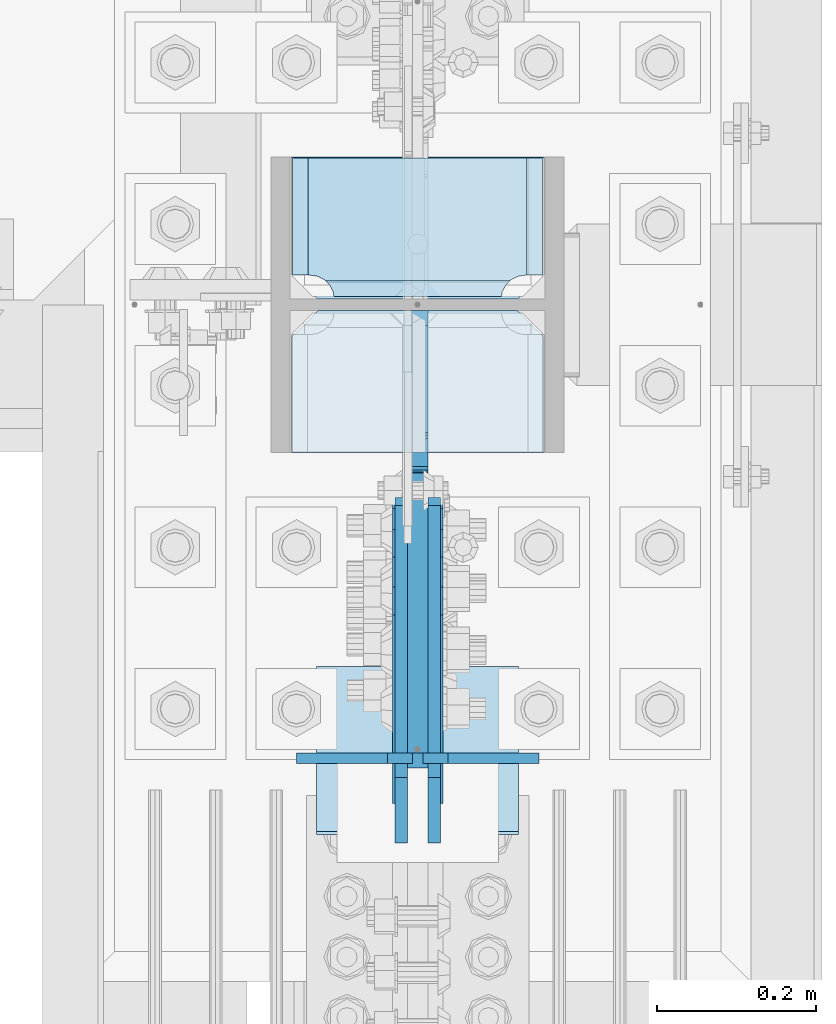
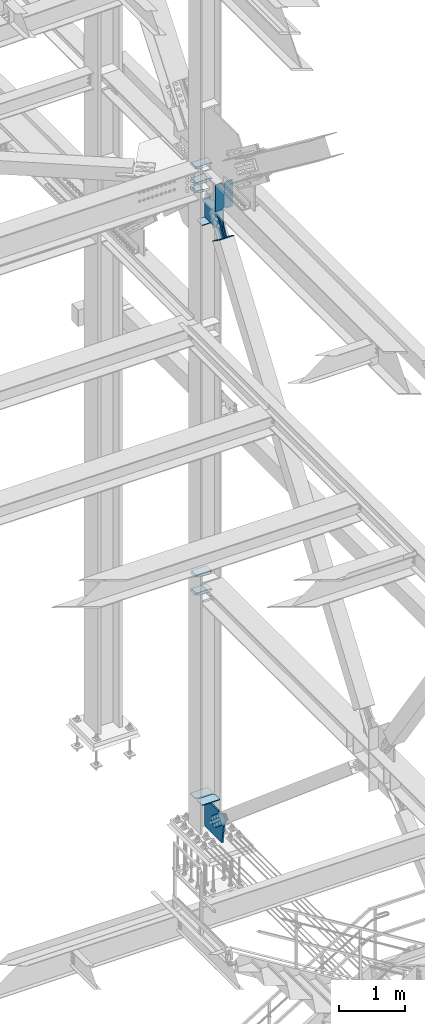
# One storey, part 3581 of 3843: 17 plates, 7 elements without a shape of their own.
"""IFC2X3 building model written with IfcOpenShell, lengths in millimetres."""

from ifc_helpers import new_model, si_unit, frame, origin_with_axes, place, context, subcontext, project, spatial, faceted_brep, material, type_object, element, aggregate, save


model = new_model("IFC2X3")

# Units and contexts
model_context = context("Model", 3, precision=1e-05, world=origin_with_axes())
body_context = subcontext(model_context, "Body", "Model", "MODEL_VIEW")
ifc_project = project(units=[si_unit("LENGTHUNIT", "METRE", prefix="MILLI"), si_unit("AREAUNIT", "SQUARE_METRE"), si_unit("VOLUMEUNIT", "CUBIC_METRE"), si_unit("MASSUNIT", "GRAM", prefix="KILO"), si_unit("TIMEUNIT", "SECOND"), si_unit("PLANEANGLEUNIT", "RADIAN"), si_unit("SOLIDANGLEUNIT", "STERADIAN"), si_unit("THERMODYNAMICTEMPERATUREUNIT", "DEGREE_CELSIUS"), si_unit("LUMINOUSINTENSITYUNIT", "LUMEN")], contexts=[model_context])

# Site, building, storey
site_placement = place(None, origin_with_axes())
site = spatial("IfcSite", under=ifc_project, at=site_placement, CompositionType="ELEMENT")
building_placement = place(site_placement, origin_with_axes())
building = spatial("IfcBuilding", under=site, at=building_placement, Name="Undefined", CompositionType="ELEMENT")
storey_placement = place(building_placement, origin_with_axes())
storey = spatial("IfcBuildingStorey", under=building, at=storey_placement, Name="Undefined", CompositionType="ELEMENT", Elevation=0.0)

# Assembly, plates
assembly_1_placement = place(storey_placement, origin_with_axes())
assembly_1 = element("IfcElementAssembly", 1, at=assembly_1_placement, inside=storey, Name="COLUMN", AssemblyPlace="NOTDEFINED", PredefinedType="RIGID_FRAME")
ifc_material_1 = material(Name="STEEL/A572-50")
plate_type_1 = type_object("IfcPlateType", PredefinedType="NOTDEFINED")
plate_1_placement = place(assembly_1_placement, frame((85807.55, 25608.75625, 41459.7600749074), z_axis=(0.0, -1.0, 0.0), x_axis=(-1.0, 0.0, 0.0)))
plate_1 = element("IfcPlate", 2, at=plate_1_placement, type_object=plate_type_1, material=ifc_material_1, Name="CB_COL", context=body_context, shape_type="Brep", body=[
    faceted_brep([(0.0, -6.34999999999854, 33.3375015258789), (0.0, -6.34999999999854, 178.59375), (0.0, 6.34999999999854, 178.59375), (0.0, 6.34999999999854, 33.3375015258789), (317.499999999985, -6.34999999999854, 178.59375), (317.499999999985, 6.34999999999854, 178.59375), (317.499999999985, -6.34999999999854, 33.3375015258789), (317.499999999985, 6.34999999999854, 33.3375015258789), (284.162498474107, -6.34999999999854, 0.0), (284.162498474107, 6.34999999999854, 0.0), (33.3375015258789, -6.34999999999854, 0.0), (33.3375015258789, 6.34999999999854, 0.0)], [[[0, 1, 2, 3]], [[1, 4, 5, 2]], [[4, 6, 7, 5]], [[6, 8, 9, 7]], [[8, 10, 11, 9]], [[10, 0, 3, 11]], [[5, 7, 9, 11, 3, 2]], [[10, 8, 6, 4, 1, 0]]]),
])
plate_2_placement = place(assembly_1_placement, frame((85807.55, 25623.04375, 30669.9559976022), z_axis=(0.0, 1.0, 0.0), x_axis=(-1.0, 0.0, 0.0)))
plate_2 = element("IfcPlate", 3, at=plate_2_placement, type_object=plate_type_1, material=ifc_material_1, Name="CB_COL", context=body_context, shape_type="Brep", body=[
    faceted_brep([(0.0, -6.34999999999854, 33.3375015258789), (0.0, -6.34999999999854, 178.59375), (0.0, 6.34999999999854, 178.59375), (0.0, 6.34999999999854, 33.3375015258789), (317.499999999985, -6.34999999999854, 178.59375), (317.499999999985, 6.34999999999854, 178.59375), (317.499999999985, -6.34999999999854, 33.3375015258789), (317.499999999985, 6.34999999999854, 33.3375015258789), (284.162498474107, -6.34999999999854, 0.0), (284.162498474107, 6.34999999999854, 0.0), (33.3375015258789, -6.34999999999854, 0.0), (33.3375015258789, 6.34999999999854, 0.0)], [[[0, 1, 2, 3]], [[1, 4, 5, 2]], [[4, 6, 7, 5]], [[6, 8, 9, 7]], [[8, 10, 11, 9]], [[10, 0, 3, 11]], [[5, 7, 9, 11, 3, 2]], [[10, 8, 6, 4, 1, 0]]]),
])
plate_3_placement = place(assembly_1_placement, frame((85807.55, 25608.75625, 30669.9559976022), z_axis=(0.0, -1.0, 0.0), x_axis=(-1.0, 0.0, 0.0)))
plate_3 = element("IfcPlate", 4, at=plate_3_placement, type_object=plate_type_1, material=ifc_material_1, Name="CB_COL", context=body_context, shape_type="Brep", body=[
    faceted_brep([(0.0, -6.34999999999854, 33.3375015258789), (0.0, -6.34999999999854, 178.59375), (0.0, 6.34999999999854, 178.59375), (0.0, 6.34999999999854, 33.3375015258789), (317.499999999985, -6.34999999999854, 178.59375), (317.499999999985, 6.34999999999854, 178.59375), (317.499999999985, -6.34999999999854, 33.3375015258789), (317.499999999985, 6.34999999999854, 33.3375015258789), (284.162498474107, -6.34999999999854, 0.0), (284.162498474107, 6.34999999999854, 0.0), (33.3375015258789, -6.34999999999854, 0.0), (33.3375015258789, 6.34999999999854, 0.0)], [[[0, 1, 2, 3]], [[1, 4, 5, 2]], [[4, 6, 7, 5]], [[6, 8, 9, 7]], [[8, 10, 11, 9]], [[10, 0, 3, 11]], [[5, 7, 9, 11, 3, 2]], [[10, 8, 6, 4, 1, 0]]]),
])
plate_type_2 = type_object("IfcPlateType", PredefinedType="NOTDEFINED")
plate_4_placement = place(assembly_1_placement, frame((85809.1375, 25800.84375, 42103.675), z_axis=(-1.0, 0.0, 0.0), x_axis=(0.0, -1.0, 0.0)))
plate_4 = element("IfcPlate", 5, at=plate_4_placement, type_object=plate_type_2, material=ifc_material_1, Name="PLATE", context=body_context, shape_type="Brep", body=[
    faceted_brep([(160.070927103505, 9.33339379637619, 49.8019750199746), (156.294129000915, 15.875, 46.0251769173919), (156.294129000915, 15.875, 274.649823082611), (160.070927103505, 9.33339379638346, 270.873024980028), (168.479274789282, -5.2302916030967, 266.588757845922), (174.625000047685, -15.875, 265.615370590487), (174.625000047685, -15.875, 55.0596294095158), (168.479274789282, -5.2302916030967, 54.0862421540805), (147.637499618526, 15.875, 21.5063709990791), (147.637499618526, -15.875, 3.17549995230729), (0.0, -15.875, 3.17549995230729), (0.0, 15.875, 21.5063709990791), (0.0, 15.875, 299.169629000906), (0.0, -15.875, 317.500500047678), (147.637499618526, -15.875, 317.500500047678), (147.637499618526, 15.875, 299.169629000906), (147.637499618531, -15.875, 295.275000381473), (147.637499618531, 15.875, 295.275000381473), (149.113757464449, -15.875, 285.954275170763), (149.113757464449, 15.875, 285.954275170763), (153.398024598551, -15.875, 277.545927484985), (153.398024598551, 15.875, 277.545927484985), (160.070927103507, -15.875, 270.873024980028), (168.479274789286, -15.875, 266.588757845922), (168.479274789286, -15.875, 54.0862421540805), (160.070927103507, -15.875, 49.8019750199746), (153.398024598551, -15.875, 43.1290725150175), (153.398024598551, 15.875, 43.1290725150175), (149.113757464449, -15.875, 34.7207248292398), (149.113757464449, 15.875, 34.7207248292398), (147.637499618531, -15.875, 25.3999996185303), (147.637499618531, 15.875, 25.3999996185303)], [[[0, 1, 2, 3, 4, 5, 6, 7]], [[8, 9, 10, 11]], [[12, 13, 14, 15]], [[13, 12, 11, 10]], [[16, 17, 15, 14]], [[16, 18, 19, 17]], [[18, 20, 21, 19]], [[21, 20, 22, 3, 2]], [[22, 23, 4, 3]], [[23, 5, 4]], [[24, 7, 6]], [[24, 25, 0, 7]], [[25, 26, 27, 1, 0]], [[26, 28, 29, 27]], [[28, 30, 31, 29]], [[31, 30, 9, 8]], [[27, 29, 31, 8, 11, 12, 15, 17, 19, 21, 2, 1]], [[9, 30, 28, 26, 25, 24, 6, 5, 23, 22, 20, 18, 16, 14, 13, 10]]]),
])
plate_5_placement = place(assembly_1_placement, frame((85809.1375, 25800.84375, 42389.425), z_axis=(-1.0, 0.0, 0.0), x_axis=(0.0, -1.0, 0.0)))
plate_5 = element("IfcPlate", 6, at=plate_5_placement, type_object=plate_type_2, material=ifc_material_1, Name="PLATE", context=body_context, shape_type="Brep", body=[
    faceted_brep([(160.070927103505, 9.33339379637619, 49.8019750199746), (156.294129000915, 15.875, 46.0251769173919), (156.294129000915, 15.875, 274.649823082611), (160.070927103505, 9.33339379638346, 270.873024980028), (168.479274789282, -5.2302916030967, 266.588757845922), (174.625000047685, -15.875, 265.615370590487), (174.625000047685, -15.875, 55.0596294095158), (168.479274789282, -5.2302916030967, 54.0862421540805), (147.637499618526, 15.875, 21.5063709990791), (147.637499618526, -15.875, 3.17549995230729), (0.0, -15.875, 3.17549995230729), (0.0, 15.875, 21.5063709990791), (0.0, 15.875, 299.169629000906), (0.0, -15.875, 317.500500047678), (147.637499618526, -15.875, 317.500500047678), (147.637499618526, 15.875, 299.169629000906), (147.637499618531, -15.875, 295.275000381473), (147.637499618531, 15.875, 295.275000381473), (149.113757464449, -15.875, 285.954275170763), (149.113757464449, 15.875, 285.954275170763), (153.398024598551, -15.875, 277.545927484985), (153.398024598551, 15.875, 277.545927484985), (160.070927103507, -15.875, 270.873024980028), (168.479274789286, -15.875, 266.588757845922), (168.479274789286, -15.875, 54.0862421540805), (160.070927103507, -15.875, 49.8019750199746), (153.398024598551, -15.875, 43.1290725150175), (153.398024598551, 15.875, 43.1290725150175), (149.113757464449, -15.875, 34.7207248292398), (149.113757464449, 15.875, 34.7207248292398), (147.637499618531, -15.875, 25.3999996185303), (147.637499618531, 15.875, 25.3999996185303)], [[[0, 1, 2, 3, 4, 5, 6, 7]], [[8, 9, 10, 11]], [[12, 13, 14, 15]], [[13, 12, 11, 10]], [[16, 17, 15, 14]], [[16, 18, 19, 17]], [[18, 20, 21, 19]], [[21, 20, 22, 3, 2]], [[22, 23, 4, 3]], [[23, 5, 4]], [[24, 7, 6]], [[24, 25, 0, 7]], [[25, 26, 27, 1, 0]], [[26, 28, 29, 27]], [[28, 30, 31, 29]], [[31, 30, 9, 8]], [[27, 29, 31, 8, 11, 12, 15, 17, 19, 21, 2, 1]], [[9, 30, 28, 26, 25, 24, 6, 5, 23, 22, 20, 18, 16, 14, 13, 10]]]),
])
plate_type_3 = type_object("IfcPlateType", PredefinedType="NOTDEFINED")
plate_6_placement = place(assembly_1_placement, frame((85488.4625, 25623.04375, 41941.75), z_axis=(0.0, 1.0, 0.0), x_axis=(1.0, 0.0, 0.0)))
plate_6 = element("IfcPlate", 7, at=plate_6_placement, type_object=plate_type_3, material=ifc_material_1, Name="PLATE", context=body_context, shape_type="Brep", body=[
    faceted_brep([(21.5053709991043, -15.875, 177.799788052507), (3.17449995233619, 15.875, 177.799755617103), (3.17449995233619, 15.875, 30.1625003814697), (21.5053709991043, -15.875, 30.1625003814661), (54.0862421540805, 5.23029160311853, 9.32072521070586), (55.0596294095158, 15.875, 3.17499995233084), (131.762500739671, 15.875, 3.17499995228718), (147.637500024415, -11.6213053312968, 19.0499992370314), (147.637500024415, -15.875, 21.5058709990553), (46.0251769173774, -15.875, 21.5058709990954), (49.8019750199892, -9.33339379635436, 17.7290728964872), (147.63750002443, -15.875, 177.799999999988), (147.63750002443, 15.875, 177.799999999988), (147.637500024415, 15.875, 19.0499992370314), (54.0862421540805, 15.875, 9.32072521070586), (49.8019750199892, 15.875, 17.7290728964872), (43.129072515032, -15.875, 24.4019754014407), (43.129072515032, 15.875, 24.4019754014407), (34.7207248292543, -15.875, 28.6862425355466), (34.7207248292543, 15.875, 28.6862425355466), (25.3999996185303, -15.875, 30.1625003814661), (25.3999996185303, 15.875, 30.1625003814661)], [[[0, 1, 2, 3]], [[4, 5, 6, 7, 8, 9, 10]], [[11, 12, 1, 0]], [[13, 12, 11, 8, 7]], [[13, 7, 6]], [[14, 5, 4]], [[15, 14, 4, 10]], [[16, 17, 15, 10, 9]], [[16, 18, 19, 17]], [[18, 20, 21, 19]], [[21, 20, 3, 2]], [[12, 13, 6, 5, 14, 15, 17, 19, 21, 2, 1]], [[20, 18, 16, 9, 8, 11, 0, 3]]]),
])
plate_type_4 = type_object("IfcPlateType", PredefinedType="NOTDEFINED")
plate_7_placement = place(assembly_1_placement, frame((85488.4625, 25623.04375, 34459.8625), z_axis=(1.0, 0.0, 0.0), x_axis=(0.0, 1.0, 0.0)))
plate_7 = element("IfcPlate", 8, at=plate_7_placement, type_object=plate_type_4, material=ifc_material_1, Name="PLATE", context=body_context, shape_type="Brep", body=[
    faceted_brep([(17.7290728964945, 7.7467605847196, 270.873024980028), (23.3384576632816, 17.4625000000015, 276.482409746808), (23.3384576632816, 17.4625000000015, 44.1925902531948), (17.7290728964945, 7.7467605847196, 49.8019750199746), (9.32072521071677, -6.81692481475329, 54.0862421540805), (3.174499952318, -17.4625000000015, 55.0597086017369), (3.174499952318, -17.4625000000015, 265.615291398266), (9.32072521071677, -6.81692481475329, 266.588757845922), (30.1625003814697, 17.4625000000015, 297.335542336717), (30.1625003814697, -17.4625000000015, 317.499500047677), (177.800000000001, -17.4625000000015, 317.499500047677), (177.800000000001, 17.4625000000015, 297.335542336717), (177.800000000001, 17.4625000000015, 23.338457663267), (177.800000000001, -17.4625000000015, 3.17449995230709), (30.1625003814697, -17.4625000000015, 3.17449995230709), (30.1625003814697, 17.4625000000015, 23.338457663267), (9.32072521071677, -17.4625000000015, 266.588757845922), (17.7290728964945, -17.4625000000015, 270.873024980028), (24.4019754014498, -17.4625000000015, 277.545927484985), (24.4019754014498, 17.4625000000015, 277.545927484985), (28.6862425355521, -17.4625000000015, 285.954275170763), (28.6862425355521, 17.4625000000015, 285.954275170763), (30.1625003814697, -17.4625000000015, 295.275000381473), (30.1625003814697, 17.4625000000015, 295.275000381473), (30.1625003814697, -17.4625000000015, 25.3999996185303), (30.1625003814697, 17.4625000000015, 25.3999996185303), (28.6862425355521, -17.4625000000015, 34.7207248292398), (28.6862425355521, 17.4625000000015, 34.7207248292398), (24.4019754014498, -17.4625000000015, 43.1290725150175), (24.4019754014498, 17.4625000000015, 43.1290725150175), (17.7290728964945, -17.4625000000015, 49.8019750199746), (9.32072521071495, -17.4625000000015, 54.0862421540805)], [[[0, 1, 2, 3, 4, 5, 6, 7]], [[8, 9, 10, 11]], [[12, 13, 14, 15]], [[16, 7, 6]], [[16, 17, 0, 7]], [[17, 18, 19, 1, 0]], [[18, 20, 21, 19]], [[20, 22, 23, 21]], [[23, 22, 9, 8]], [[11, 10, 13, 12]], [[24, 25, 15, 14]], [[24, 26, 27, 25]], [[26, 28, 29, 27]], [[29, 28, 30, 3, 2]], [[30, 31, 4, 3]], [[31, 5, 4]], [[19, 21, 23, 8, 11, 12, 15, 25, 27, 29, 2, 1]], [[31, 30, 28, 26, 24, 14, 13, 10, 9, 22, 20, 18, 17, 16, 6, 5]]]),
])
plate_8_placement = place(assembly_1_placement, frame((85488.4625, 25623.04375, 34793.2375), z_axis=(1.0, 0.0, 0.0), x_axis=(0.0, 1.0, 0.0)))
plate_8 = element("IfcPlate", 9, at=plate_8_placement, type_object=plate_type_4, material=ifc_material_1, Name="PLATE", context=body_context, shape_type="Brep", body=[
    faceted_brep([(17.7290728964945, 7.7467605847196, 270.873024980028), (23.3384576632816, 17.4625000000015, 276.482409746808), (23.3384576632816, 17.4625000000015, 44.1925902531948), (17.7290728964945, 7.7467605847196, 49.8019750199746), (9.32072521071677, -6.81692481475329, 54.0862421540805), (3.174499952318, -17.4625000000015, 55.0597086017369), (3.174499952318, -17.4625000000015, 265.615291398266), (9.32072521071677, -6.81692481475329, 266.588757845922), (30.1625003814697, 17.4625000000015, 297.335542336717), (30.1625003814697, -17.4625000000015, 317.499500047677), (177.800000000001, -17.4625000000015, 317.499500047677), (177.800000000001, 17.4625000000015, 297.335542336717), (177.800000000001, 17.4625000000015, 23.338457663267), (177.800000000001, -17.4625000000015, 3.17449995230709), (30.1625003814697, -17.4625000000015, 3.17449995230709), (30.1625003814697, 17.4625000000015, 23.338457663267), (9.32072521071677, -17.4625000000015, 266.588757845922), (17.7290728964945, -17.4625000000015, 270.873024980028), (24.4019754014498, -17.4625000000015, 277.545927484985), (24.4019754014498, 17.4625000000015, 277.545927484985), (28.6862425355521, -17.4625000000015, 285.954275170763), (28.6862425355521, 17.4625000000015, 285.954275170763), (30.1625003814697, -17.4625000000015, 295.275000381473), (30.1625003814697, 17.4625000000015, 295.275000381473), (30.1625003814697, -17.4625000000015, 25.3999996185303), (30.1625003814697, 17.4625000000015, 25.3999996185303), (28.6862425355521, -17.4625000000015, 34.7207248292398), (28.6862425355521, 17.4625000000015, 34.7207248292398), (24.4019754014498, -17.4625000000015, 43.1290725150175), (24.4019754014498, 17.4625000000015, 43.1290725150175), (17.7290728964945, -17.4625000000015, 49.8019750199746), (9.32072521071495, -17.4625000000015, 54.0862421540805)], [[[0, 1, 2, 3, 4, 5, 6, 7]], [[8, 9, 10, 11]], [[12, 13, 14, 15]], [[16, 7, 6]], [[16, 17, 0, 7]], [[17, 18, 19, 1, 0]], [[18, 20, 21, 19]], [[20, 22, 23, 21]], [[23, 22, 9, 8]], [[11, 10, 13, 12]], [[24, 25, 15, 14]], [[24, 26, 27, 25]], [[26, 28, 29, 27]], [[29, 28, 30, 3, 2]], [[30, 31, 4, 3]], [[31, 5, 4]], [[19, 21, 23, 8, 11, 12, 15, 25, 27, 29, 2, 1]], [[31, 30, 28, 26, 24, 14, 13, 10, 9, 22, 20, 18, 17, 16, 6, 5]]]),
])

assembly_2_placement = place(storey_placement, origin_with_axes())
assembly_2 = element("IfcElementAssembly", 10, at=assembly_2_placement, inside=storey, Name="BEAM", AssemblyPlace="NOTDEFINED", PredefinedType="RIGID_FRAME")
plate_type_5 = type_object("IfcPlateType", PredefinedType="NOTDEFINED")
plate_9_placement = place(assembly_2_placement, frame((85642.45, 25045.9881160896, 41948.1), z_axis=(0.0, 0.0, 1.0), x_axis=(-1.0, 0.0, 0.0)))
plate_9 = element("IfcPlate", 11, at=plate_9_placement, type_object=plate_type_5, material=ifc_material_1, Name="PLATE", context=body_context, shape_type="Brep", body=[
    faceted_brep([(0.0, -6.35000000000582, 31.75), (0.0, -6.35000000000582, 466.724999999999), (0.0, 6.35000000000582, 466.724999999999), (0.0, 6.35000000000582, 31.75), (31.75, -6.35000000000582, 498.474999999999), (31.75, 6.35000000000582, 498.474999999999), (146.050003051758, -6.34999999999854, 498.474993896481), (146.050003051758, 6.34999999999854, 498.474993896481), (146.050003051758, -6.34999999999854, 0.0), (146.050003051758, 6.34999999999854, 0.0), (31.75, -6.35000000000582, 0.0), (31.75, 6.35000000000582, 0.0)], [[[0, 1, 2, 3]], [[1, 4, 5, 2]], [[4, 6, 7, 5]], [[6, 8, 9, 7]], [[8, 10, 11, 9]], [[10, 0, 3, 11]], [[5, 7, 9, 11, 3, 2]], [[10, 8, 6, 4, 1, 0]]]),
])
plate_10_placement = place(assembly_2_placement, frame((85655.15, 25045.9881160896, 41948.1), z_axis=(0.0, 0.0, 1.0), x_axis=(1.0, 0.0, 0.0)))
plate_10 = element("IfcPlate", 12, at=plate_10_placement, type_object=plate_type_5, material=ifc_material_1, Name="PLATE", context=body_context, shape_type="Brep", body=[
    faceted_brep([(0.0, -6.35000000000582, 31.75), (0.0, -6.35000000000582, 466.724999999999), (0.0, 6.35000000000582, 466.724999999999), (0.0, 6.35000000000582, 31.75), (31.75, -6.35000000000582, 498.474999999999), (31.75, 6.35000000000582, 498.474999999999), (146.050003051758, -6.34999999999854, 498.474993896481), (146.050003051758, 6.34999999999854, 498.474993896481), (146.050003051758, -6.34999999999854, 0.0), (146.050003051758, 6.34999999999854, 0.0), (31.75, -6.35000000000582, 0.0), (31.75, 6.35000000000582, 0.0)], [[[0, 1, 2, 3]], [[1, 4, 5, 2]], [[4, 6, 7, 5]], [[6, 8, 9, 7]], [[8, 10, 11, 9]], [[10, 0, 3, 11]], [[5, 7, 9, 11, 3, 2]], [[10, 8, 6, 4, 1, 0]]]),
])
aggregate(assembly_2, [plate_9, plate_10])

# Assembly, plate
assembly_3_placement = place(storey_placement, origin_with_axes())
assembly_3 = element("IfcElementAssembly", 13, at=assembly_3_placement, inside=storey, AssemblyPlace="NOTDEFINED", PredefinedType="RIGID_FRAME")
ifc_material_2 = material(Name="STEEL/A36")
plate_type_6 = type_object("IfcPlateType", PredefinedType="NOTDEFINED")
plate_11_placement = place(assembly_3_placement, frame((85626.575, 25118.787576137, 41350.4419368445), z_axis=(0.0, -0.818771907061984, 0.574118946043485), x_axis=(0.0, 0.57411894604347, 0.818771907061994)))
plate_11 = element("IfcPlate", 14, at=plate_11_placement, type_object=plate_type_6, material=ifc_material_2, context=body_context, shape_type="Brep", body=[
    faceted_brep([(0.0, -9.52500000000146, 0.0), (1.71894498635083e-09, -9.52499999999418, 158.39421297863), (1.71894498635083e-09, 9.52499999999418, 158.39421297863), (0.0, 9.52500000000146, 0.0), (69.8500000010408, -9.52499999999418, 158.394212979103), (69.8500000010408, 9.52499999999418, 158.394212979103), (171.450000002631, -9.52499999999418, 176.034606488582), (171.450000002631, 9.52499999999418, 176.034606488582), (390.129297671807, -9.52499999999418, 176.034606487716), (390.129297671807, 9.52499999999418, 176.034606487716), (427.187405137312, -9.52499999999418, 168.663290600991), (427.187405137312, 9.52499999999418, 168.663290600991), (458.60375167372, -9.52499999999418, 147.671558963724), (458.60375167372, 9.52499999999418, 147.671558963724), (479.59548331075, -9.52499999999418, 116.255212427161), (479.59548331075, 9.52499999999418, 116.255212427161), (486.966799197198, -9.52499999999418, 79.1971080138683), (486.966799197198, 9.52499999999418, 79.1971080138683), (479.595483310488, -9.52499999999418, 42.1390005483336), (479.595483310488, 9.52499999999418, 42.1390005483336), (458.603751673207, -9.52499999999418, 10.7226540119082), (458.603751673207, 9.52499999999418, 10.7226540119082), (427.18740513661, -9.52499999999418, -10.2690776251402), (427.18740513661, 9.52499999999418, -10.2690776251402), (390.129299195723, -9.52499999999418, -17.6403935115741), (390.129299195723, 9.52499999999418, -17.6403935115741), (171.450000001962, -9.52499999999418, -17.6403935107155), (171.450000001962, 9.52499999999418, -17.6403935107155), (69.8499999979995, -9.52499999999418, -4.00177668780088e-10), (69.8499999979995, 9.52499999999418, -4.00177668780088e-10)], [[[0, 1, 2, 3]], [[1, 4, 5, 2]], [[4, 6, 7, 5]], [[6, 8, 9, 7]], [[8, 10, 11, 9]], [[10, 12, 13, 11]], [[12, 14, 15, 13]], [[14, 16, 17, 15]], [[16, 18, 19, 17]], [[18, 20, 21, 19]], [[20, 22, 23, 21]], [[22, 24, 25, 23]], [[24, 26, 27, 25]], [[26, 28, 29, 27]], [[28, 0, 3, 29]], [[5, 7, 9, 11, 13, 15, 17, 19, 21, 23, 25, 27, 29, 3, 2]], [[28, 26, 24, 22, 20, 18, 16, 14, 12, 10, 8, 6, 4, 1, 0]]]),
])
aggregate(assembly_3, [plate_11])

assembly_4_placement = place(storey_placement, origin_with_axes())
assembly_4 = element("IfcElementAssembly", 15, at=assembly_4_placement, inside=storey, AssemblyPlace="NOTDEFINED", PredefinedType="RIGID_FRAME")
plate_12_placement = place(assembly_4_placement, frame((85671.025, 25118.787576137, 41350.4419368445), z_axis=(0.0, -0.818771907061984, 0.574118946043485), x_axis=(0.0, 0.57411894604347, 0.818771907061994)))
plate_12 = element("IfcPlate", 16, at=plate_12_placement, type_object=plate_type_6, material=ifc_material_2, context=body_context, shape_type="Brep", body=[
    faceted_brep([(0.0, -9.52500000000146, 0.0), (1.71894498635083e-09, -9.52499999999418, 158.39421297863), (1.71894498635083e-09, 9.52499999999418, 158.39421297863), (0.0, 9.52500000000146, 0.0), (69.8500000010408, -9.52499999999418, 158.394212979103), (69.8500000010408, 9.52499999999418, 158.394212979103), (171.450000002631, -9.52499999999418, 176.034606488582), (171.450000002631, 9.52499999999418, 176.034606488582), (390.129297671807, -9.52499999999418, 176.034606487716), (390.129297671807, 9.52499999999418, 176.034606487716), (427.187405137312, -9.52499999999418, 168.663290600991), (427.187405137312, 9.52499999999418, 168.663290600991), (458.60375167372, -9.52499999999418, 147.671558963724), (458.60375167372, 9.52499999999418, 147.671558963724), (479.59548331075, -9.52499999999418, 116.255212427161), (479.59548331075, 9.52499999999418, 116.255212427161), (486.966799197198, -9.52499999999418, 79.1971080138683), (486.966799197198, 9.52499999999418, 79.1971080138683), (479.595483310488, -9.52499999999418, 42.1390005483336), (479.595483310488, 9.52499999999418, 42.1390005483336), (458.603751673207, -9.52499999999418, 10.7226540119082), (458.603751673207, 9.52499999999418, 10.7226540119082), (427.18740513661, -9.52499999999418, -10.2690776251402), (427.18740513661, 9.52499999999418, -10.2690776251402), (390.129299195723, -9.52499999999418, -17.6403935115741), (390.129299195723, 9.52499999999418, -17.6403935115741), (171.450000001962, -9.52499999999418, -17.6403935107155), (171.450000001962, 9.52499999999418, -17.6403935107155), (69.8499999979995, -9.52499999999418, -4.00177668780088e-10), (69.8499999979995, 9.52499999999418, -4.00177668780088e-10)], [[[0, 1, 2, 3]], [[1, 4, 5, 2]], [[4, 6, 7, 5]], [[6, 8, 9, 7]], [[8, 10, 11, 9]], [[10, 12, 13, 11]], [[12, 14, 15, 13]], [[14, 16, 17, 15]], [[16, 18, 19, 17]], [[18, 20, 21, 19]], [[20, 22, 23, 21]], [[22, 24, 25, 23]], [[24, 26, 27, 25]], [[26, 28, 29, 27]], [[28, 0, 3, 29]], [[5, 7, 9, 11, 13, 15, 17, 19, 21, 23, 25, 27, 29, 3, 2]], [[28, 26, 24, 22, 20, 18, 16, 14, 12, 10, 8, 6, 4, 1, 0]]]),
])
aggregate(assembly_4, [plate_12])

assembly_5_placement = place(storey_placement, origin_with_axes())
assembly_5 = element("IfcElementAssembly", 17, at=assembly_5_placement, inside=storey, Name="Plate", AssemblyPlace="NOTDEFINED", PredefinedType="RIGID_FRAME")
plate_type_7 = type_object("IfcPlateType", PredefinedType="NOTDEFINED")
plate_13_placement = place(assembly_5_placement, frame((85775.8, 25159.750070442, 41325.5969905511), z_axis=(0.0, -0.818771907061984, 0.574118946043485), x_axis=(-1.0, 0.0, 0.0)))
plate_13 = element("IfcPlate", 18, at=plate_13_placement, type_object=plate_type_7, material=ifc_material_2, Name="Plate", context=body_context, shape_type="Brep", body=[
    faceted_brep([(0.0, -3.17499999999927, 0.0), (0.0, -3.17499999965185, 254.000000005151), (0.0, 3.17500000035216, 254.000000005166), (0.0, 3.17499999999927, 0.0), (254.0, -3.17499999965185, 254.000000005151), (254.0, 3.17500000035216, 254.000000005166), (254.0, -3.17500000000291, 0.0), (254.0, 3.17499999999927, 1.45519152283669e-11)], [[[0, 1, 2, 3]], [[1, 4, 5, 2]], [[4, 6, 7, 5]], [[6, 0, 3, 7]], [[5, 7, 3, 2]], [[6, 4, 1, 0]]]),
])
aggregate(assembly_5, [plate_13])

assembly_6_placement = place(storey_placement, origin_with_axes())
assembly_6 = element("IfcElementAssembly", 19, at=assembly_6_placement, inside=storey, AssemblyPlace="NOTDEFINED", PredefinedType="RIGID_FRAME")
plate_type_8 = type_object("IfcPlateType", PredefinedType="NOTDEFINED")
plate_14_placement = place(assembly_6_placement, frame((85628.1625, 25021.901171308, 30722.936446603), z_axis=(0.0, -0.645737502174364, -0.763559479206181), x_axis=(0.0, 0.76355947920618, -0.645737502174365)))
plate_14 = element("IfcPlate", 20, at=plate_14_placement, type_object=plate_type_8, material=ifc_material_2, context=body_context, shape_type="Brep", body=[
    faceted_brep([(0.0, -7.9375, 0.0), (-4.01087163481861e-10, -7.9375, 127.507304269042), (-4.01087163481861e-10, 7.9375, 127.507304269042), (0.0, 7.9375, 0.0), (69.8499999986043, -7.9375, 127.507304268976), (69.8499999986043, 7.9375, 127.507304268976), (171.449999997779, -7.9375, 159.003652133302), (171.449999997779, 7.9375, 159.003652133302), (390.771138851001, -7.9375, 159.003652133724), (390.771138851001, 7.9375, 159.003652133724), (427.221735783516, -7.9375, 151.753177605606), (427.221735783516, 7.9375, 151.753177605606), (458.123059758641, -7.9375, 131.105573042281), (458.123059758641, 7.9375, 131.105573042281), (478.770664322428, -7.9375, 100.204249067465), (478.770664322428, 7.9375, 100.204249067465), (486.021138851092, -7.9375, 63.75365213646), (486.021138851092, 7.9375, 63.75365213646), (478.770664323177, -7.9375, 27.3030552033888), (478.770664323177, 7.9375, 27.3030552033888), (458.123059759649, -7.9375, -3.59826877222076), (458.123059759649, 7.9375, -3.59826877222076), (427.221735784352, -7.9375, -24.2458733362073), (427.221735784352, 7.9375, -24.2458733362073), (390.771138852427, -7.9375, -31.496347864675), (390.771138852427, 7.9375, -31.496347864675), (171.450000000242, -7.9375, -31.4963478651116), (171.450000000242, 7.9375, -31.4963478651116), (69.850000000486, -7.9375, 2.91038304567337e-11), (69.850000000486, 7.9375, 2.91038304567337e-11)], [[[0, 1, 2, 3]], [[1, 4, 5, 2]], [[4, 6, 7, 5]], [[6, 8, 9, 7]], [[8, 10, 11, 9]], [[10, 12, 13, 11]], [[12, 14, 15, 13]], [[14, 16, 17, 15]], [[16, 18, 19, 17]], [[18, 20, 21, 19]], [[20, 22, 23, 21]], [[22, 24, 25, 23]], [[24, 26, 27, 25]], [[26, 28, 29, 27]], [[28, 0, 3, 29]], [[5, 7, 9, 11, 13, 15, 17, 19, 21, 23, 25, 27, 29, 3, 2]], [[28, 26, 24, 22, 20, 18, 16, 14, 12, 10, 8, 6, 4, 1, 0]]]),
])
aggregate(assembly_6, [plate_14])

assembly_7_placement = place(storey_placement, origin_with_axes())
assembly_7 = element("IfcElementAssembly", 21, at=assembly_7_placement, inside=storey, AssemblyPlace="NOTDEFINED", PredefinedType="RIGID_FRAME")
plate_15_placement = place(assembly_7_placement, frame((85669.4375, 25021.901171308, 30722.936446603), z_axis=(0.0, -0.645737502174364, -0.763559479206181), x_axis=(0.0, 0.76355947920618, -0.645737502174365)))
plate_15 = element("IfcPlate", 22, at=plate_15_placement, type_object=plate_type_8, material=ifc_material_2, context=body_context, shape_type="Brep", body=[
    faceted_brep([(0.0, -7.9375, 0.0), (-4.01087163481861e-10, -7.9375, 127.507304269042), (-4.01087163481861e-10, 7.9375, 127.507304269042), (0.0, 7.9375, 0.0), (69.8499999986043, -7.9375, 127.507304268976), (69.8499999986043, 7.9375, 127.507304268976), (171.449999997779, -7.9375, 159.003652133302), (171.449999997779, 7.9375, 159.003652133302), (390.771138851001, -7.9375, 159.003652133724), (390.771138851001, 7.9375, 159.003652133724), (427.221735783516, -7.9375, 151.753177605606), (427.221735783516, 7.9375, 151.753177605606), (458.123059758641, -7.9375, 131.105573042281), (458.123059758641, 7.9375, 131.105573042281), (478.770664322428, -7.9375, 100.204249067465), (478.770664322428, 7.9375, 100.204249067465), (486.021138851092, -7.9375, 63.75365213646), (486.021138851092, 7.9375, 63.75365213646), (478.770664323177, -7.9375, 27.3030552033888), (478.770664323177, 7.9375, 27.3030552033888), (458.123059759649, -7.9375, -3.59826877222076), (458.123059759649, 7.9375, -3.59826877222076), (427.221735784352, -7.9375, -24.2458733362073), (427.221735784352, 7.9375, -24.2458733362073), (390.771138852427, -7.9375, -31.496347864675), (390.771138852427, 7.9375, -31.496347864675), (171.450000000242, -7.9375, -31.4963478651116), (171.450000000242, 7.9375, -31.4963478651116), (69.850000000486, -7.9375, 2.91038304567337e-11), (69.850000000486, 7.9375, 2.91038304567337e-11)], [[[0, 1, 2, 3]], [[1, 4, 5, 2]], [[4, 6, 7, 5]], [[6, 8, 9, 7]], [[8, 10, 11, 9]], [[10, 12, 13, 11]], [[12, 14, 15, 13]], [[14, 16, 17, 15]], [[16, 18, 19, 17]], [[18, 20, 21, 19]], [[20, 22, 23, 21]], [[22, 24, 25, 23]], [[24, 26, 27, 25]], [[26, 28, 29, 27]], [[28, 0, 3, 29]], [[5, 7, 9, 11, 13, 15, 17, 19, 21, 23, 25, 27, 29, 3, 2]], [[28, 26, 24, 22, 20, 18, 16, 14, 12, 10, 8, 6, 4, 1, 0]]]),
])
aggregate(assembly_7, [plate_15])

# Plate
plate_type_9 = type_object("IfcPlateType", PredefinedType="NOTDEFINED")
plate_16_placement = place(assembly_1_placement, frame((85648.8, 25608.75625, 30137.1), z_axis=(0.0, 0.0, 1.0), x_axis=(0.0, -1.0, 0.0)))
plate_16 = element("IfcPlate", 23, at=plate_16_placement, type_object=plate_type_9, material=ifc_material_1, Name="CB", context=body_context, shape_type="Brep", body=[
    faceted_brep([(0.0, -12.6999999999971, 19.0499992370605), (0.0, -12.6999999999971, 507.455998365116), (0.0, 12.6999999999971, 507.455998365116), (0.0, 12.6999999999971, 19.0499992370605), (19.0499992370605, -12.6999999999971, 526.505997602177), (19.0499992370605, 12.6999999999971, 526.505997602177), (412.490006052205, -12.6999999999971, 526.505997602177), (412.490006052205, 12.6999999999971, 526.505997602177), (575.019159705098, -12.6999999999971, 334.321595269725), (575.019159705098, 12.6999999999971, 334.321595269725), (527.049999999999, -12.6999999999971, 0.0), (527.049999999999, 12.6999999999971, 0.0), (19.0500015258731, -12.6999999999971, -6.33008312433958e-10), (19.0500015258731, 12.6999999999971, 0.0)], [[[0, 1, 2, 3]], [[1, 4, 5, 2]], [[4, 6, 7, 5]], [[6, 8, 9, 7]], [[8, 10, 11, 9]], [[10, 12, 13, 11]], [[12, 0, 3, 13]], [[5, 7, 9, 11, 13, 3, 2]], [[12, 10, 8, 6, 4, 1, 0]]]),
])

plate_type_10 = type_object("IfcPlateType", PredefinedType="NOTDEFINED")
plate_17_placement = place(assembly_1_placement, frame((85648.8, 25052.2912725912, 41925.875), z_axis=(0.0, 0.0, -1.0), x_axis=(0.0, 1.0, 0.0)))
plate_17 = element("IfcPlate", 24, at=plate_17_placement, type_object=plate_type_10, material=ifc_material_1, Name="CB", context=body_context, shape_type="Brep", body=[
    faceted_brep([(352.471227408831, -12.6999999999971, 0.0), (352.471227408831, 12.6999999999971, 0.0), (352.471227408831, 12.6999999999971, 25.4000001907334), (352.471227408831, -12.6999999999971, 25.4000001907334), (353.437957331418, 12.6999999999971, 30.2600797087798), (353.437957331418, -12.6999999999971, 30.2600797087798), (356.190971231896, 12.6999999999971, 34.3802561769335), (356.190971231896, -12.6999999999971, 34.3802561769335), (360.311147700049, 12.6999999999971, 37.1332700774074), (360.311147700049, -12.6999999999971, 37.1332700774074), (365.171227218096, 12.6999999999971, 38.0999999999985), (365.171227218096, -12.6999999999971, 38.0999999999985), (390.571227599565, 12.6999999999971, 38.0999999999985), (390.571227599565, -12.6999999999971, 38.0999999999985), (395.431307117611, 12.6999999999971, 37.1332700774074), (395.431307117611, -12.6999999999971, 37.1332700774074), (399.551483585765, 12.6999999999971, 34.3802561769335), (399.551483585765, -12.6999999999971, 34.3802561769335), (402.304497486242, 12.6999999999971, 30.2600797087798), (402.304497486242, -12.6999999999971, 30.2600797087798), (403.27122740883, -12.6999999999971, 25.4000001907334), (403.27122740883, 12.6999999999971, 25.4000001907334), (403.27122740883, 12.6999999999971, 0.0), (403.27122740883, -12.6999999999971, 0.0), (0.0, -12.6999999999971, 0.0), (0.0, -12.6999999999971, 319.407195758635), (0.0, 12.6999999999971, 319.407195758635), (0.0, 12.6999999999971, 0.0), (200.169261978983, -12.6999999999971, 459.764925092619), (200.169261978983, 12.6999999999971, 459.764925092619), (537.414978171772, -12.6999999999971, 459.764925092619), (537.414978171772, 12.6999999999971, 459.764925092619), (556.464977408832, -12.6999999999971, 440.714925855558), (556.464977408832, 12.6999999999971, 440.714925855558), (556.464977408832, -12.6999999999971, 19.0499992370605), (556.464977408832, 12.6999999999971, 19.0499992370605), (537.414978171772, -12.6999999999971, 0.0), (537.414978171772, 12.6999999999971, 0.0)], [[[0, 1, 2, 3]], [[3, 2, 4, 5]], [[5, 4, 6, 7]], [[7, 6, 8, 9]], [[9, 8, 10, 11]], [[11, 10, 12, 13]], [[13, 12, 14, 15]], [[15, 14, 16, 17]], [[17, 16, 18, 19]], [[20, 21, 22, 23]], [[19, 18, 21, 20]], [[24, 25, 26, 27]], [[25, 28, 29, 26]], [[28, 30, 31, 29]], [[30, 32, 33, 31]], [[32, 34, 35, 33]], [[34, 36, 37, 35]], [[37, 36, 23, 22]], [[16, 14, 12, 10, 8, 6, 4, 2, 1, 27, 26, 29, 31, 33, 35, 37, 22, 21, 18]], [[24, 27, 1, 0]], [[36, 34, 32, 30, 28, 25, 24, 0, 3, 5, 7, 9, 11, 13, 15, 17, 19, 20, 23]]]),
])

aggregate(assembly_1, [plate_6, plate_7, plate_8, plate_4, plate_5, plate_1, plate_17, plate_2, plate_3, plate_16])

save(model, "model.ifc")
